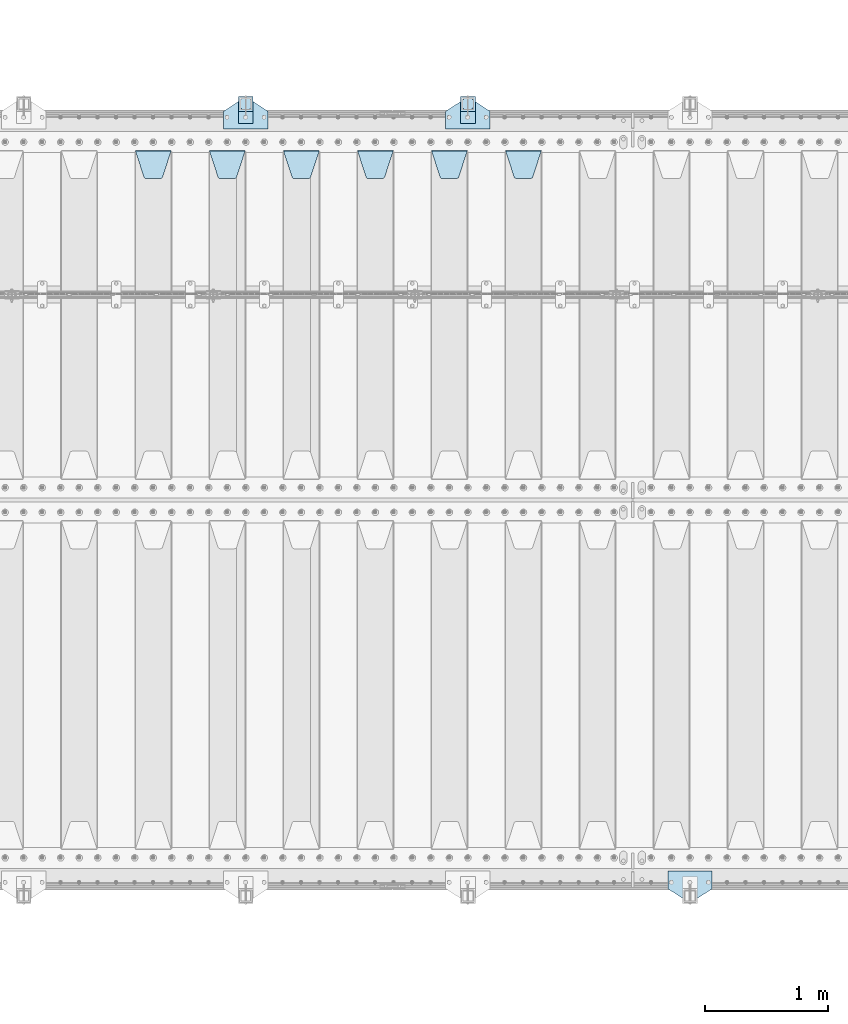
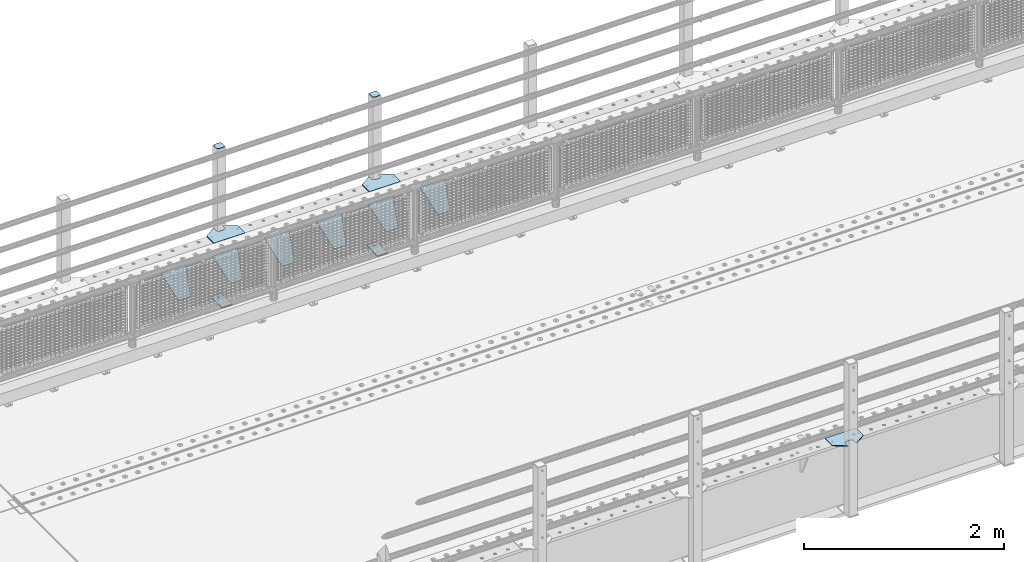
# One storey, part 204 of 242: 15 plates.
"""IFC2X3 building model written with IfcOpenShell, lengths in millimetres."""

from ifc_helpers import new_model, si_unit, frame, origin_with_axes, place, context, subcontext, project, spatial, faceted_brep, material, type_object, element, save


model = new_model("IFC2X3")

# Units and contexts
model_context = context("Model", 3, precision=1e-05, world=origin_with_axes())
body_context = subcontext(model_context, "Body", "Model", "MODEL_VIEW")
ifc_project = project(units=[si_unit("LENGTHUNIT", "METRE", prefix="MILLI"), si_unit("AREAUNIT", "SQUARE_METRE"), si_unit("VOLUMEUNIT", "CUBIC_METRE"), si_unit("MASSUNIT", "GRAM", prefix="KILO"), si_unit("TIMEUNIT", "SECOND"), si_unit("PLANEANGLEUNIT", "RADIAN"), si_unit("SOLIDANGLEUNIT", "STERADIAN"), si_unit("THERMODYNAMICTEMPERATUREUNIT", "DEGREE_CELSIUS"), si_unit("LUMINOUSINTENSITYUNIT", "LUMEN")], contexts=[model_context])

# Site, building, storey
site_placement = place(None, origin_with_axes())
site = spatial("IfcSite", under=ifc_project, at=site_placement, CompositionType="ELEMENT")
building_placement = place(site_placement, origin_with_axes())
building = spatial("IfcBuilding", under=site, at=building_placement, Name="Standard", CompositionType="ELEMENT")
storey_placement = place(building_placement, origin_with_axes())
storey = spatial("IfcBuildingStorey", under=building, at=storey_placement, Name="Undefined", CompositionType="ELEMENT", Elevation=0.0)

# Plates
ifc_material_1 = material(Name="STEEL/S355J2")
plate_type_1 = type_object("IfcPlateType", PredefinedType="NOTDEFINED")
plate_1_placement = place(storey_placement, frame((-36680.0, -17995.0, 5.00000000004911), z_axis=(0.0, 1.0, 0.0), x_axis=(1.0, 0.0, 0.0)))
element("IfcPlate", 1, at=plate_1_placement, inside=storey, type_object=plate_type_1, material=ifc_material_1, context=body_context, shape_type="Brep", body=[
    faceted_brep([(0.0, -5.0, 0.0), (2.31396552408114e-06, -5.0, 145.0), (2.31396552408114e-06, 5.0, 145.0), (0.0, 5.0, 0.0), (130.0, -5.0, 230.0), (130.0, 5.0, 230.0), (130.0, -5.0, 180.0), (130.0, 5.0, 180.0), (130.48036798992, -5.0, 175.122741949595), (130.48036798992, 5.0, 175.122741949595), (131.903011687216, -5.0, 170.432914190871), (131.903011687216, 5.0, 170.432914190871), (134.213259692435, -5.0, 166.110744174512), (134.213259692435, 5.0, 166.110744174512), (137.322330470335, -5.0, 162.322330470335), (137.322330470335, 5.0, 162.322330470335), (141.110744174512, -5.0, 159.213259692435), (141.110744174512, 5.0, 159.213259692435), (145.432914190871, -5.0, 156.903011687216), (145.432914190871, 5.0, 156.903011687216), (150.122741949595, -5.0, 155.48036798992), (150.122741949595, 5.0, 155.48036798992), (155.0, -5.0, 155.0), (155.0, 5.0, 155.0), (205.0, -5.0, 155.0), (205.0, 5.0, 155.0), (209.877258050405, -5.0, 155.48036798992), (209.877258050405, 5.0, 155.48036798992), (214.567085809129, -5.0, 156.903011687216), (214.567085809129, 5.0, 156.903011687216), (218.889255825488, -5.0, 159.213259692435), (218.889255825488, 5.0, 159.213259692435), (222.677669529665, -5.0, 162.322330470335), (222.677669529665, 5.0, 162.322330470335), (225.786740307565, -5.0, 166.110744174512), (225.786740307565, 5.0, 166.110744174512), (228.096988312784, -5.0, 170.432914190871), (228.096988312784, 5.0, 170.432914190871), (229.51963201008, -5.0, 175.122741949595), (229.51963201008, 5.0, 175.122741949595), (230.0, -5.0, 180.0), (230.0, 5.0, 180.0), (230.0, -5.0, 230.0), (230.0, 5.0, 230.0), (360.0, -5.0, 145.0), (360.0, 5.0, 145.0), (360.0, -5.0, -7.27595761418343e-12), (360.0, 5.0, -7.27595761418343e-12)], [[[0, 1, 2, 3]], [[1, 4, 5, 2]], [[4, 6, 7, 5]], [[6, 8, 9, 7]], [[8, 10, 11, 9]], [[10, 12, 13, 11]], [[12, 14, 15, 13]], [[14, 16, 17, 15]], [[16, 18, 19, 17]], [[18, 20, 21, 19]], [[20, 22, 23, 21]], [[22, 24, 25, 23]], [[24, 26, 27, 25]], [[26, 28, 29, 27]], [[28, 30, 31, 29]], [[30, 32, 33, 31]], [[32, 34, 35, 33]], [[34, 36, 37, 35]], [[36, 38, 39, 37]], [[38, 40, 41, 39]], [[40, 42, 43, 41]], [[42, 44, 45, 43]], [[44, 46, 47, 45]], [[46, 0, 3, 47]], [[5, 7, 9, 11, 13, 15, 17, 19, 21, 23, 25, 27, 29, 31, 33, 35, 37, 39, 41, 43, 45, 47, 3, 2]], [[46, 44, 42, 40, 38, 36, 34, 32, 30, 28, 26, 24, 22, 20, 18, 16, 14, 12, 10, 8, 6, 4, 1, 0]]]),
])
plate_2_placement = place(storey_placement, frame((-38480.0, -17995.0, 5.00000000004911), z_axis=(0.0, 1.0, 0.0), x_axis=(1.0, 0.0, 0.0)))
element("IfcPlate", 2, at=plate_2_placement, inside=storey, type_object=plate_type_1, material=ifc_material_1, context=body_context, shape_type="Brep", body=[
    faceted_brep([(0.0, -5.0, 0.0), (2.31396552408114e-06, -5.0, 145.0), (2.31396552408114e-06, 5.0, 145.0), (0.0, 5.0, 0.0), (130.0, -5.0, 230.0), (130.0, 5.0, 230.0), (130.0, -5.0, 180.0), (130.0, 5.0, 180.0), (130.48036798992, -5.0, 175.122741949595), (130.48036798992, 5.0, 175.122741949595), (131.903011687216, -5.0, 170.432914190871), (131.903011687216, 5.0, 170.432914190871), (134.213259692435, -5.0, 166.110744174512), (134.213259692435, 5.0, 166.110744174512), (137.322330470335, -5.0, 162.322330470335), (137.322330470335, 5.0, 162.322330470335), (141.110744174512, -5.0, 159.213259692435), (141.110744174512, 5.0, 159.213259692435), (145.432914190871, -5.0, 156.903011687216), (145.432914190871, 5.0, 156.903011687216), (150.122741949595, -5.0, 155.48036798992), (150.122741949595, 5.0, 155.48036798992), (155.0, -5.0, 155.0), (155.0, 5.0, 155.0), (205.0, -5.0, 155.0), (205.0, 5.0, 155.0), (209.877258050405, -5.0, 155.48036798992), (209.877258050405, 5.0, 155.48036798992), (214.567085809129, -5.0, 156.903011687216), (214.567085809129, 5.0, 156.903011687216), (218.889255825488, -5.0, 159.213259692435), (218.889255825488, 5.0, 159.213259692435), (222.677669529665, -5.0, 162.322330470335), (222.677669529665, 5.0, 162.322330470335), (225.786740307565, -5.0, 166.110744174512), (225.786740307565, 5.0, 166.110744174512), (228.096988312784, -5.0, 170.432914190871), (228.096988312784, 5.0, 170.432914190871), (229.51963201008, -5.0, 175.122741949595), (229.51963201008, 5.0, 175.122741949595), (230.0, -5.0, 180.0), (230.0, 5.0, 180.0), (230.0, -5.0, 230.0), (230.0, 5.0, 230.0), (360.0, -5.0, 145.0), (360.0, 5.0, 145.0), (360.0, -5.0, -7.27595761418343e-12), (360.0, 5.0, -7.27595761418343e-12)], [[[0, 1, 2, 3]], [[1, 4, 5, 2]], [[4, 6, 7, 5]], [[6, 8, 9, 7]], [[8, 10, 11, 9]], [[10, 12, 13, 11]], [[12, 14, 15, 13]], [[14, 16, 17, 15]], [[16, 18, 19, 17]], [[18, 20, 21, 19]], [[20, 22, 23, 21]], [[22, 24, 25, 23]], [[24, 26, 27, 25]], [[26, 28, 29, 27]], [[28, 30, 31, 29]], [[30, 32, 33, 31]], [[32, 34, 35, 33]], [[34, 36, 37, 35]], [[36, 38, 39, 37]], [[38, 40, 41, 39]], [[40, 42, 43, 41]], [[42, 44, 45, 43]], [[44, 46, 47, 45]], [[46, 0, 3, 47]], [[5, 7, 9, 11, 13, 15, 17, 19, 21, 23, 25, 27, 29, 31, 33, 35, 37, 39, 41, 43, 45, 47, 3, 2]], [[46, 44, 42, 40, 38, 36, 34, 32, 30, 28, 26, 24, 22, 20, 18, 16, 14, 12, 10, 8, 6, 4, 1, 0]]]),
])
plate_3_placement = place(storey_placement, frame((-34520.0, -24005.0, 5.00000000004911), z_axis=(0.0, -1.0, 0.0), x_axis=(-1.0, 0.0, 0.0)))
element("IfcPlate", 3, at=plate_3_placement, inside=storey, type_object=plate_type_1, material=ifc_material_1, context=body_context, shape_type="Brep", body=[
    faceted_brep([(0.0, -5.0, 0.0), (2.31396552408114e-06, -5.0, 145.0), (2.31396552408114e-06, 5.0, 145.0), (0.0, 5.0, 0.0), (130.0, -5.0, 230.0), (130.0, 5.0, 230.0), (130.0, -5.0, 180.0), (130.0, 5.0, 180.0), (130.48036798992, -5.0, 175.122741949595), (130.48036798992, 5.0, 175.122741949595), (131.903011687216, -5.0, 170.432914190871), (131.903011687216, 5.0, 170.432914190871), (134.213259692435, -5.0, 166.110744174512), (134.213259692435, 5.0, 166.110744174512), (137.322330470335, -5.0, 162.322330470335), (137.322330470335, 5.0, 162.322330470335), (141.110744174512, -5.0, 159.213259692435), (141.110744174512, 5.0, 159.213259692435), (145.432914190871, -5.0, 156.903011687216), (145.432914190871, 5.0, 156.903011687216), (150.122741949595, -5.0, 155.48036798992), (150.122741949595, 5.0, 155.48036798992), (155.0, -5.0, 155.0), (155.0, 5.0, 155.0), (205.0, -5.0, 155.0), (205.0, 5.0, 155.0), (209.877258050405, -5.0, 155.48036798992), (209.877258050405, 5.0, 155.48036798992), (214.567085809129, -5.0, 156.903011687216), (214.567085809129, 5.0, 156.903011687216), (218.889255825488, -5.0, 159.213259692435), (218.889255825488, 5.0, 159.213259692435), (222.677669529665, -5.0, 162.322330470335), (222.677669529665, 5.0, 162.322330470335), (225.786740307565, -5.0, 166.110744174512), (225.786740307565, 5.0, 166.110744174512), (228.096988312784, -5.0, 170.432914190871), (228.096988312784, 5.0, 170.432914190871), (229.51963201008, -5.0, 175.122741949595), (229.51963201008, 5.0, 175.122741949595), (230.0, -5.0, 180.0), (230.0, 5.0, 180.0), (230.0, -5.0, 230.0), (230.0, 5.0, 230.0), (360.0, -5.0, 145.0), (360.0, 5.0, 145.0), (360.0, -5.0, -7.27595761418343e-12), (360.0, 5.0, -7.27595761418343e-12)], [[[0, 1, 2, 3]], [[1, 4, 5, 2]], [[4, 6, 7, 5]], [[6, 8, 9, 7]], [[8, 10, 11, 9]], [[10, 12, 13, 11]], [[12, 14, 15, 13]], [[14, 16, 17, 15]], [[16, 18, 19, 17]], [[18, 20, 21, 19]], [[20, 22, 23, 21]], [[22, 24, 25, 23]], [[24, 26, 27, 25]], [[26, 28, 29, 27]], [[28, 30, 31, 29]], [[30, 32, 33, 31]], [[32, 34, 35, 33]], [[34, 36, 37, 35]], [[36, 38, 39, 37]], [[38, 40, 41, 39]], [[40, 42, 43, 41]], [[42, 44, 45, 43]], [[44, 46, 47, 45]], [[46, 0, 3, 47]], [[5, 7, 9, 11, 13, 15, 17, 19, 21, 23, 25, 27, 29, 31, 33, 35, 37, 39, 41, 43, 45, 47, 3, 2]], [[46, 44, 42, 40, 38, 36, 34, 32, 30, 28, 26, 24, 22, 20, 18, 16, 14, 12, 10, 8, 6, 4, 1, 0]]]),
])
plate_type_2 = type_object("IfcPlateType", PredefinedType="NOTDEFINED")
for number, where, z_axis, x_axis in (
    (4, (-36559.9999999999, -17949.9999999998, -850.000000000002), (0.0, 1.0, 0.0), (1.0, 0.0, 0.0)),
    (5, (-38359.9999999999, -17949.9999999998, -850.000000000002), (0.0, 1.0, 0.0), (1.0, 0.0, 0.0)),
):
    element("IfcPlate", number, at=place(storey_placement, frame(where, z_axis=z_axis, x_axis=x_axis)), inside=storey, type_object=plate_type_2, material=ifc_material_1, context=body_context, shape_type="Brep", body=[
        faceted_brep([(66.3639610305399, -5.0, 163.636038969114), (66.3639610305399, 5.0, 163.636038969114), (59.9999999998618, 5.0, 160.999999999793), (59.9999999998618, -5.0, 160.999999999793), (53.6360389691836, 5.0, 163.636038969114), (53.6360389691836, -5.0, 163.636038969114), (50.9999999998618, 5.0, 169.999999999793), (50.9999999998618, -5.0, 169.999999999793), (53.6360389691836, 5.0, 176.363961030471), (53.6360389691836, -5.0, 176.363961030471), (59.9999999998618, 5.0, 178.999999999793), (59.9999999998618, -5.0, 178.999999999793), (66.3639610305399, 5.0, 176.363961030471), (66.3639610305399, -5.0, 176.363961030471), (68.9999999998618, 5.0, 169.999999999793), (68.9999999998618, -5.0, 169.999999999793), (120.0, -5.0, 0.0), (120.0, -5.0, 220.0), (0.0, -5.0, 220.0), (0.0, -5.0, 0.0), (0.0, 5.0, 0.0), (120.0, 5.0, 0.0), (120.0, 5.0, 220.0), (0.0, 5.0, 220.0)], [[[0, 1, 2, 3]], [[3, 2, 4, 5]], [[5, 4, 6, 7]], [[7, 6, 8, 9]], [[9, 8, 10, 11]], [[11, 10, 12, 13]], [[13, 12, 14, 15]], [[15, 14, 1, 0]], [[16, 17, 18, 19], [11, 13, 15, 0, 3, 5, 7, 9]], [[16, 19, 20, 21]], [[17, 16, 21, 22]], [[18, 17, 22, 23]], [[19, 18, 23, 20]], [[22, 21, 20, 23], [2, 1, 14, 12, 10, 8, 6, 4]]]),
    ])
plate_type_3 = type_object("IfcPlateType", PredefinedType="NOTDEFINED")
plate_4_placement = place(storey_placement, frame((-36455.9999999999, -17833.9999999998, 1012.50000000001), z_axis=(0.0, 1.0, 0.0), x_axis=(-1.0, 0.0, 0.0)))
element("IfcPlate", 6, at=plate_4_placement, inside=storey, type_object=plate_type_3, material=ifc_material_1, context=body_context, shape_type="Brep", body=[
    faceted_brep([(0.0, -2.5, 19.0), (0.0, -2.5, 69.0), (0.0, 2.5, 69.0), (0.0, 2.5, 19.0), (0.476369668544066, -2.5, 73.2278977451715), (0.476369668544066, 2.5, 73.2278977451715), (1.88159150985302, -2.5, 77.2437910432345), (1.88159150985302, 2.5, 77.2437910432345), (4.14520183310742, -2.5, 80.8463062353148), (4.14520183310742, 2.5, 80.8463062353148), (7.15369376468516, -2.5, 83.8547981668926), (7.15369376468516, 2.5, 83.8547981668926), (10.7562089567655, -2.5, 86.118408490147), (10.7562089567655, 2.5, 86.118408490147), (14.7721022548285, -2.5, 87.5236303314559), (14.7721022548285, 2.5, 87.5236303314559), (19.0, -2.5, 88.0), (19.0, 2.5, 88.0), (69.0, -2.5, 88.0), (69.0, 2.5, 88.0), (73.2278977451715, -2.5, 87.5236303314559), (73.2278977451715, 2.5, 87.5236303314559), (77.2437910432345, -2.5, 86.118408490147), (77.2437910432345, 2.5, 86.118408490147), (80.8463062353148, -2.5, 83.8547981668926), (80.8463062353148, 2.5, 83.8547981668926), (83.8547981668926, -2.5, 80.8463062353148), (83.8547981668926, 2.5, 80.8463062353148), (86.118408490147, -2.5, 77.2437910432345), (86.118408490147, 2.5, 77.2437910432345), (87.5236303314559, -2.5, 73.2278977451715), (87.5236303314559, 2.5, 73.2278977451715), (88.0, -2.5, 69.0), (88.0, 2.5, 69.0), (88.0, -2.5, 19.0), (88.0, 2.5, 19.0), (87.5236303314559, -2.5, 14.7721022548285), (87.5236303314559, 2.5, 14.7721022548285), (86.118408490147, -2.5, 10.7562089567655), (86.118408490147, 2.5, 10.7562089567655), (83.8547981668926, -2.5, 7.15369376468516), (83.8547981668926, 2.5, 7.15369376468516), (80.8463062353148, -2.5, 4.14520183310742), (80.8463062353148, 2.5, 4.14520183310742), (77.2437910432345, -2.5, 1.88159150985302), (77.2437910432345, 2.5, 1.88159150985302), (73.2278977451715, -2.5, 0.476369668544066), (73.2278977451715, 2.5, 0.476369668544066), (69.0, -2.5, 0.0), (69.0, 2.5, 0.0), (19.0, -2.5, 0.0), (19.0, 2.5, 0.0), (14.7721022548285, -2.5, 0.476369668544066), (14.7721022548285, 2.5, 0.476369668544066), (10.7562089567655, -2.5, 1.88159150985302), (10.7562089567655, 2.5, 1.88159150985302), (7.15369376468516, -2.5, 4.14520183310742), (7.15369376468516, 2.5, 4.14520183310742), (4.14520183310742, -2.5, 7.15369376468516), (4.14520183310742, 2.5, 7.15369376468516), (1.88159150985302, -2.5, 10.7562089567655), (1.88159150985302, 2.5, 10.7562089567655), (0.476369668544066, -2.5, 14.7721022548285), (0.476369668544066, 2.5, 14.7721022548285)], [[[0, 1, 2, 3]], [[1, 4, 5, 2]], [[4, 6, 7, 5]], [[6, 8, 9, 7]], [[8, 10, 11, 9]], [[10, 12, 13, 11]], [[12, 14, 15, 13]], [[14, 16, 17, 15]], [[16, 18, 19, 17]], [[18, 20, 21, 19]], [[20, 22, 23, 21]], [[22, 24, 25, 23]], [[24, 26, 27, 25]], [[26, 28, 29, 27]], [[28, 30, 31, 29]], [[30, 32, 33, 31]], [[32, 34, 35, 33]], [[34, 36, 37, 35]], [[36, 38, 39, 37]], [[38, 40, 41, 39]], [[40, 42, 43, 41]], [[42, 44, 45, 43]], [[44, 46, 47, 45]], [[46, 48, 49, 47]], [[48, 50, 51, 49]], [[50, 52, 53, 51]], [[52, 54, 55, 53]], [[54, 56, 57, 55]], [[56, 58, 59, 57]], [[58, 60, 61, 59]], [[60, 62, 63, 61]], [[62, 0, 3, 63]], [[5, 7, 9, 11, 13, 15, 17, 19, 21, 23, 25, 27, 29, 31, 33, 35, 37, 39, 41, 43, 45, 47, 49, 51, 53, 55, 57, 59, 61, 63, 3, 2]], [[62, 60, 58, 56, 54, 52, 50, 48, 46, 44, 42, 40, 38, 36, 34, 32, 30, 28, 26, 24, 22, 20, 18, 16, 14, 12, 10, 8, 6, 4, 1, 0]]]),
])
plate_5_placement = place(storey_placement, frame((-38255.9999999999, -17833.9999999998, 1012.50000000001), z_axis=(0.0, 1.0, 0.0), x_axis=(-1.0, 0.0, 0.0)))
element("IfcPlate", 7, at=plate_5_placement, inside=storey, type_object=plate_type_3, material=ifc_material_1, context=body_context, shape_type="Brep", body=[
    faceted_brep([(0.0, -2.5, 19.0), (0.0, -2.5, 69.0), (0.0, 2.5, 69.0), (0.0, 2.5, 19.0), (0.476369668544066, -2.5, 73.2278977451715), (0.476369668544066, 2.5, 73.2278977451715), (1.88159150985302, -2.5, 77.2437910432345), (1.88159150985302, 2.5, 77.2437910432345), (4.14520183310742, -2.5, 80.8463062353148), (4.14520183310742, 2.5, 80.8463062353148), (7.15369376468516, -2.5, 83.8547981668926), (7.15369376468516, 2.5, 83.8547981668926), (10.7562089567655, -2.5, 86.118408490147), (10.7562089567655, 2.5, 86.118408490147), (14.7721022548285, -2.5, 87.5236303314559), (14.7721022548285, 2.5, 87.5236303314559), (19.0, -2.5, 88.0), (19.0, 2.5, 88.0), (69.0, -2.5, 88.0), (69.0, 2.5, 88.0), (73.2278977451715, -2.5, 87.5236303314559), (73.2278977451715, 2.5, 87.5236303314559), (77.2437910432345, -2.5, 86.118408490147), (77.2437910432345, 2.5, 86.118408490147), (80.8463062353148, -2.5, 83.8547981668926), (80.8463062353148, 2.5, 83.8547981668926), (83.8547981668926, -2.5, 80.8463062353148), (83.8547981668926, 2.5, 80.8463062353148), (86.118408490147, -2.5, 77.2437910432345), (86.118408490147, 2.5, 77.2437910432345), (87.5236303314559, -2.5, 73.2278977451715), (87.5236303314559, 2.5, 73.2278977451715), (88.0, -2.5, 69.0), (88.0, 2.5, 69.0), (88.0, -2.5, 19.0), (88.0, 2.5, 19.0), (87.5236303314559, -2.5, 14.7721022548285), (87.5236303314559, 2.5, 14.7721022548285), (86.118408490147, -2.5, 10.7562089567655), (86.118408490147, 2.5, 10.7562089567655), (83.8547981668926, -2.5, 7.15369376468516), (83.8547981668926, 2.5, 7.15369376468516), (80.8463062353148, -2.5, 4.14520183310742), (80.8463062353148, 2.5, 4.14520183310742), (77.2437910432345, -2.5, 1.88159150985302), (77.2437910432345, 2.5, 1.88159150985302), (73.2278977451715, -2.5, 0.476369668544066), (73.2278977451715, 2.5, 0.476369668544066), (69.0, -2.5, 0.0), (69.0, 2.5, 0.0), (19.0, -2.5, 0.0), (19.0, 2.5, 0.0), (14.7721022548285, -2.5, 0.476369668544066), (14.7721022548285, 2.5, 0.476369668544066), (10.7562089567655, -2.5, 1.88159150985302), (10.7562089567655, 2.5, 1.88159150985302), (7.15369376468516, -2.5, 4.14520183310742), (7.15369376468516, 2.5, 4.14520183310742), (4.14520183310742, -2.5, 7.15369376468516), (4.14520183310742, 2.5, 7.15369376468516), (1.88159150985302, -2.5, 10.7562089567655), (1.88159150985302, 2.5, 10.7562089567655), (0.476369668544066, -2.5, 14.7721022548285), (0.476369668544066, 2.5, 14.7721022548285)], [[[0, 1, 2, 3]], [[1, 4, 5, 2]], [[4, 6, 7, 5]], [[6, 8, 9, 7]], [[8, 10, 11, 9]], [[10, 12, 13, 11]], [[12, 14, 15, 13]], [[14, 16, 17, 15]], [[16, 18, 19, 17]], [[18, 20, 21, 19]], [[20, 22, 23, 21]], [[22, 24, 25, 23]], [[24, 26, 27, 25]], [[26, 28, 29, 27]], [[28, 30, 31, 29]], [[30, 32, 33, 31]], [[32, 34, 35, 33]], [[34, 36, 37, 35]], [[36, 38, 39, 37]], [[38, 40, 41, 39]], [[40, 42, 43, 41]], [[42, 44, 45, 43]], [[44, 46, 47, 45]], [[46, 48, 49, 47]], [[48, 50, 51, 49]], [[50, 52, 53, 51]], [[52, 54, 55, 53]], [[54, 56, 57, 55]], [[56, 58, 59, 57]], [[58, 60, 61, 59]], [[60, 62, 63, 61]], [[62, 0, 3, 63]], [[5, 7, 9, 11, 13, 15, 17, 19, 21, 23, 25, 27, 29, 31, 33, 35, 37, 39, 41, 43, 45, 47, 49, 51, 53, 55, 57, 59, 61, 63, 3, 2]], [[62, 60, 58, 56, 54, 52, 50, 48, 46, 44, 42, 40, 38, 36, 34, 32, 30, 28, 26, 24, 22, 20, 18, 16, 14, 12, 10, 8, 6, 4, 1, 0]]]),
])
plate_type_4 = type_object("IfcPlateType", PredefinedType="NOTDEFINED")
for number, where, z_axis, x_axis in (
    (8, (-36559.9999999999, -17949.9999999998, -857.500000000002), (0.0, 1.0, 0.0), (1.0, 0.0, 0.0)),
    (9, (-38359.9999999999, -17949.9999999998, -857.500000000002), (0.0, 1.0, 0.0), (1.0, 0.0, 0.0)),
):
    element("IfcPlate", number, at=place(storey_placement, frame(where, z_axis=z_axis, x_axis=x_axis)), inside=storey, type_object=plate_type_4, material=ifc_material_1, context=body_context, shape_type="Brep", body=[
        faceted_brep([(0.0, -2.5, 0.0), (0.0, -2.5, 100.0), (0.0, 2.5, 100.0), (0.0, 2.5, 0.0), (120.0, -2.5, 100.0), (120.0, 2.5, 100.0), (120.0, -2.5, 0.0), (120.0, 2.5, 0.0)], [[[0, 1, 2, 3]], [[1, 4, 5, 2]], [[4, 6, 7, 5]], [[6, 0, 3, 7]], [[5, 7, 3, 2]], [[6, 4, 1, 0]]]),
    ])
ifc_material_2 = material(Name="STEEL/S355N")
plate_type_5 = type_object("IfcPlateType", PredefinedType="NOTDEFINED")
plate_6_placement = place(storey_placement, frame((-36195.0, -18168.2322330441, -1.76776695296576), z_axis=(0.0, -0.707106781186547, -0.707106781186548), x_axis=(1.0, 0.0, 0.0)))
element("IfcPlate", 10, at=plate_6_placement, inside=storey, type_object=plate_type_5, material=ifc_material_2, context=body_context, shape_type="Brep", body=[
    faceted_brep([(0.0, -2.5, 0.0), (69.345504679477, -2.50000000000182, 300.171731424829), (69.345504679477, 2.5, 300.171731424829), (0.0, 2.5, 0.0), (70.9274061199576, -2.5, 304.897442415398), (70.9274061199576, 2.5, 304.897442415398), (73.3818627772307, -2.5, 309.234538108525), (73.3818627772307, 2.50000000000182, 309.234538108529), (76.6187032999551, -2.5, 313.023683126101), (76.6187032999551, 2.50000000000182, 313.023683126103), (80.5190132704993, -2.5, 316.12567259537), (80.5190132704993, 2.5, 316.12567259537), (84.9395038596849, -2.5, 318.426546230474), (84.9395038596849, 2.50000000000182, 318.426546230476), (89.7177759439219, -2.49999999999818, 319.841774983273), (89.7177759439219, 2.50000000000182, 319.841774983273), (94.678286292652, -2.5, 320.319366455076), (94.678286292652, 2.5, 320.319366455076), (195.321713707348, -2.5, 320.319366455076), (195.321713707348, 2.5, 320.319366455076), (200.282224056078, -2.5, 319.841774983272), (200.282224056078, 2.50000000000182, 319.841774983273), (205.060496140315, -2.5, 318.426546230474), (205.060496140315, 2.49999999999818, 318.426546230474), (209.480986729501, -2.49999999999818, 316.12567259537), (209.480986729501, 2.5, 316.12567259537), (213.381296700045, -2.5, 313.023683126101), (213.381296700045, 2.49999999999818, 313.023683126101), (216.618137222769, -2.5, 309.234538108525), (216.618137222769, 2.5, 309.234538108523), (219.072593880042, -2.49999999999818, 304.897442415398), (219.072593880042, 2.50000000000182, 304.897442415398), (220.654495320523, -2.50000000000182, 300.171731424829), (220.654495320523, 2.5, 300.171731424829), (290.0, -2.5, 0.0), (290.0, 2.5, -1.81898940354586e-12)], [[[0, 1, 2, 3]], [[1, 4, 5, 2]], [[4, 6, 7, 5]], [[6, 8, 9, 7]], [[8, 10, 11, 9]], [[10, 12, 13, 11]], [[12, 14, 15, 13]], [[14, 16, 17, 15]], [[16, 18, 19, 17]], [[18, 20, 21, 19]], [[20, 22, 23, 21]], [[22, 24, 25, 23]], [[24, 26, 27, 25]], [[26, 28, 29, 27]], [[28, 30, 31, 29]], [[30, 32, 33, 31]], [[32, 34, 35, 33]], [[34, 0, 3, 35]], [[5, 7, 9, 11, 13, 15, 17, 19, 21, 23, 25, 27, 29, 31, 33, 35, 3, 2]], [[34, 32, 30, 28, 26, 24, 22, 20, 18, 16, 14, 12, 10, 8, 6, 4, 1, 0]]]),
])
plate_7_placement = place(storey_placement, frame((-36795.0, -18168.2322330441, -1.76776695296576), z_axis=(0.0, -0.707106781186547, -0.707106781186548), x_axis=(1.0, 0.0, 0.0)))
element("IfcPlate", 11, at=plate_7_placement, inside=storey, type_object=plate_type_5, material=ifc_material_2, context=body_context, shape_type="Brep", body=[
    faceted_brep([(0.0, -2.5, 0.0), (69.345504679477, -2.50000000000182, 300.171731424829), (69.345504679477, 2.5, 300.171731424829), (0.0, 2.5, 0.0), (70.9274061199576, -2.5, 304.897442415398), (70.9274061199576, 2.5, 304.897442415398), (73.3818627772307, -2.5, 309.234538108525), (73.3818627772307, 2.50000000000182, 309.234538108529), (76.6187032999551, -2.5, 313.023683126101), (76.6187032999551, 2.50000000000182, 313.023683126103), (80.5190132704993, -2.5, 316.12567259537), (80.5190132704993, 2.5, 316.12567259537), (84.9395038596849, -2.5, 318.426546230474), (84.9395038596849, 2.50000000000182, 318.426546230476), (89.7177759439219, -2.49999999999818, 319.841774983273), (89.7177759439219, 2.50000000000182, 319.841774983273), (94.678286292652, -2.5, 320.319366455076), (94.678286292652, 2.5, 320.319366455076), (195.321713707348, -2.5, 320.319366455076), (195.321713707348, 2.5, 320.319366455076), (200.282224056078, -2.5, 319.841774983272), (200.282224056078, 2.50000000000182, 319.841774983273), (205.060496140315, -2.5, 318.426546230474), (205.060496140315, 2.49999999999818, 318.426546230474), (209.480986729501, -2.49999999999818, 316.12567259537), (209.480986729501, 2.5, 316.12567259537), (213.381296700045, -2.5, 313.023683126101), (213.381296700045, 2.49999999999818, 313.023683126101), (216.618137222769, -2.5, 309.234538108525), (216.618137222769, 2.5, 309.234538108523), (219.072593880042, -2.49999999999818, 304.897442415398), (219.072593880042, 2.50000000000182, 304.897442415398), (220.654495320523, -2.50000000000182, 300.171731424829), (220.654495320523, 2.5, 300.171731424829), (290.0, -2.5, 0.0), (290.0, 2.5, -1.81898940354586e-12)], [[[0, 1, 2, 3]], [[1, 4, 5, 2]], [[4, 6, 7, 5]], [[6, 8, 9, 7]], [[8, 10, 11, 9]], [[10, 12, 13, 11]], [[12, 14, 15, 13]], [[14, 16, 17, 15]], [[16, 18, 19, 17]], [[18, 20, 21, 19]], [[20, 22, 23, 21]], [[22, 24, 25, 23]], [[24, 26, 27, 25]], [[26, 28, 29, 27]], [[28, 30, 31, 29]], [[30, 32, 33, 31]], [[32, 34, 35, 33]], [[34, 0, 3, 35]], [[5, 7, 9, 11, 13, 15, 17, 19, 21, 23, 25, 27, 29, 31, 33, 35, 3, 2]], [[34, 32, 30, 28, 26, 24, 22, 20, 18, 16, 14, 12, 10, 8, 6, 4, 1, 0]]]),
])
plate_8_placement = place(storey_placement, frame((-37395.0, -18168.2322330441, -1.76776695296576), z_axis=(0.0, -0.707106781186547, -0.707106781186548), x_axis=(1.0, 0.0, 0.0)))
element("IfcPlate", 12, at=plate_8_placement, inside=storey, type_object=plate_type_5, material=ifc_material_2, context=body_context, shape_type="Brep", body=[
    faceted_brep([(0.0, -2.5, 0.0), (69.345504679477, -2.50000000000182, 300.171731424829), (69.345504679477, 2.5, 300.171731424829), (0.0, 2.5, 0.0), (70.9274061199576, -2.5, 304.897442415398), (70.9274061199576, 2.5, 304.897442415398), (73.3818627772307, -2.5, 309.234538108525), (73.3818627772307, 2.50000000000182, 309.234538108529), (76.6187032999551, -2.5, 313.023683126101), (76.6187032999551, 2.50000000000182, 313.023683126103), (80.5190132704993, -2.5, 316.12567259537), (80.5190132704993, 2.5, 316.12567259537), (84.9395038596849, -2.5, 318.426546230474), (84.9395038596849, 2.50000000000182, 318.426546230476), (89.7177759439219, -2.49999999999818, 319.841774983273), (89.7177759439219, 2.50000000000182, 319.841774983273), (94.678286292652, -2.5, 320.319366455076), (94.678286292652, 2.5, 320.319366455076), (195.321713707348, -2.5, 320.319366455076), (195.321713707348, 2.5, 320.319366455076), (200.282224056078, -2.5, 319.841774983272), (200.282224056078, 2.50000000000182, 319.841774983273), (205.060496140315, -2.5, 318.426546230474), (205.060496140315, 2.49999999999818, 318.426546230474), (209.480986729501, -2.49999999999818, 316.12567259537), (209.480986729501, 2.5, 316.12567259537), (213.381296700045, -2.5, 313.023683126101), (213.381296700045, 2.49999999999818, 313.023683126101), (216.618137222769, -2.5, 309.234538108525), (216.618137222769, 2.5, 309.234538108523), (219.072593880042, -2.49999999999818, 304.897442415398), (219.072593880042, 2.50000000000182, 304.897442415398), (220.654495320523, -2.50000000000182, 300.171731424829), (220.654495320523, 2.5, 300.171731424829), (290.0, -2.5, 0.0), (290.0, 2.5, -1.81898940354586e-12)], [[[0, 1, 2, 3]], [[1, 4, 5, 2]], [[4, 6, 7, 5]], [[6, 8, 9, 7]], [[8, 10, 11, 9]], [[10, 12, 13, 11]], [[12, 14, 15, 13]], [[14, 16, 17, 15]], [[16, 18, 19, 17]], [[18, 20, 21, 19]], [[20, 22, 23, 21]], [[22, 24, 25, 23]], [[24, 26, 27, 25]], [[26, 28, 29, 27]], [[28, 30, 31, 29]], [[30, 32, 33, 31]], [[32, 34, 35, 33]], [[34, 0, 3, 35]], [[5, 7, 9, 11, 13, 15, 17, 19, 21, 23, 25, 27, 29, 31, 33, 35, 3, 2]], [[34, 32, 30, 28, 26, 24, 22, 20, 18, 16, 14, 12, 10, 8, 6, 4, 1, 0]]]),
])
plate_9_placement = place(storey_placement, frame((-37995.0, -18168.2322330441, -1.76776695296576), z_axis=(0.0, -0.707106781186547, -0.707106781186548), x_axis=(1.0, 0.0, 0.0)))
element("IfcPlate", 13, at=plate_9_placement, inside=storey, type_object=plate_type_5, material=ifc_material_2, context=body_context, shape_type="Brep", body=[
    faceted_brep([(0.0, -2.5, 0.0), (69.345504679477, -2.50000000000182, 300.171731424829), (69.345504679477, 2.5, 300.171731424829), (0.0, 2.5, 0.0), (70.9274061199576, -2.5, 304.897442415398), (70.9274061199576, 2.5, 304.897442415398), (73.3818627772307, -2.5, 309.234538108525), (73.3818627772307, 2.50000000000182, 309.234538108529), (76.6187032999551, -2.5, 313.023683126101), (76.6187032999551, 2.50000000000182, 313.023683126103), (80.5190132704993, -2.5, 316.12567259537), (80.5190132704993, 2.5, 316.12567259537), (84.9395038596849, -2.5, 318.426546230474), (84.9395038596849, 2.50000000000182, 318.426546230476), (89.7177759439219, -2.49999999999818, 319.841774983273), (89.7177759439219, 2.50000000000182, 319.841774983273), (94.678286292652, -2.5, 320.319366455076), (94.678286292652, 2.5, 320.319366455076), (195.321713707348, -2.5, 320.319366455076), (195.321713707348, 2.5, 320.319366455076), (200.282224056078, -2.5, 319.841774983272), (200.282224056078, 2.50000000000182, 319.841774983273), (205.060496140315, -2.5, 318.426546230474), (205.060496140315, 2.49999999999818, 318.426546230474), (209.480986729501, -2.49999999999818, 316.12567259537), (209.480986729501, 2.5, 316.12567259537), (213.381296700045, -2.5, 313.023683126101), (213.381296700045, 2.49999999999818, 313.023683126101), (216.618137222769, -2.5, 309.234538108525), (216.618137222769, 2.5, 309.234538108523), (219.072593880042, -2.49999999999818, 304.897442415398), (219.072593880042, 2.50000000000182, 304.897442415398), (220.654495320523, -2.50000000000182, 300.171731424829), (220.654495320523, 2.5, 300.171731424829), (290.0, -2.5, 0.0), (290.0, 2.5, -1.81898940354586e-12)], [[[0, 1, 2, 3]], [[1, 4, 5, 2]], [[4, 6, 7, 5]], [[6, 8, 9, 7]], [[8, 10, 11, 9]], [[10, 12, 13, 11]], [[12, 14, 15, 13]], [[14, 16, 17, 15]], [[16, 18, 19, 17]], [[18, 20, 21, 19]], [[20, 22, 23, 21]], [[22, 24, 25, 23]], [[24, 26, 27, 25]], [[26, 28, 29, 27]], [[28, 30, 31, 29]], [[30, 32, 33, 31]], [[32, 34, 35, 33]], [[34, 0, 3, 35]], [[5, 7, 9, 11, 13, 15, 17, 19, 21, 23, 25, 27, 29, 31, 33, 35, 3, 2]], [[34, 32, 30, 28, 26, 24, 22, 20, 18, 16, 14, 12, 10, 8, 6, 4, 1, 0]]]),
])
plate_10_placement = place(storey_placement, frame((-38595.0, -18168.2322330441, -1.76776695296576), z_axis=(0.0, -0.707106781186547, -0.707106781186548), x_axis=(1.0, 0.0, 0.0)))
element("IfcPlate", 14, at=plate_10_placement, inside=storey, type_object=plate_type_5, material=ifc_material_2, context=body_context, shape_type="Brep", body=[
    faceted_brep([(0.0, -2.5, 0.0), (69.345504679477, -2.50000000000182, 300.171731424829), (69.345504679477, 2.5, 300.171731424829), (0.0, 2.5, 0.0), (70.9274061199576, -2.5, 304.897442415398), (70.9274061199576, 2.5, 304.897442415398), (73.3818627772307, -2.5, 309.234538108525), (73.3818627772307, 2.50000000000182, 309.234538108529), (76.6187032999551, -2.5, 313.023683126101), (76.6187032999551, 2.50000000000182, 313.023683126103), (80.5190132704993, -2.5, 316.12567259537), (80.5190132704993, 2.5, 316.12567259537), (84.9395038596849, -2.5, 318.426546230474), (84.9395038596849, 2.50000000000182, 318.426546230476), (89.7177759439219, -2.49999999999818, 319.841774983273), (89.7177759439219, 2.50000000000182, 319.841774983273), (94.678286292652, -2.5, 320.319366455076), (94.678286292652, 2.5, 320.319366455076), (195.321713707348, -2.5, 320.319366455076), (195.321713707348, 2.5, 320.319366455076), (200.282224056078, -2.5, 319.841774983272), (200.282224056078, 2.50000000000182, 319.841774983273), (205.060496140315, -2.5, 318.426546230474), (205.060496140315, 2.49999999999818, 318.426546230474), (209.480986729501, -2.49999999999818, 316.12567259537), (209.480986729501, 2.5, 316.12567259537), (213.381296700045, -2.5, 313.023683126101), (213.381296700045, 2.49999999999818, 313.023683126101), (216.618137222769, -2.5, 309.234538108525), (216.618137222769, 2.5, 309.234538108523), (219.072593880042, -2.49999999999818, 304.897442415398), (219.072593880042, 2.50000000000182, 304.897442415398), (220.654495320523, -2.50000000000182, 300.171731424829), (220.654495320523, 2.5, 300.171731424829), (290.0, -2.5, 0.0), (290.0, 2.5, -1.81898940354586e-12)], [[[0, 1, 2, 3]], [[1, 4, 5, 2]], [[4, 6, 7, 5]], [[6, 8, 9, 7]], [[8, 10, 11, 9]], [[10, 12, 13, 11]], [[12, 14, 15, 13]], [[14, 16, 17, 15]], [[16, 18, 19, 17]], [[18, 20, 21, 19]], [[20, 22, 23, 21]], [[22, 24, 25, 23]], [[24, 26, 27, 25]], [[26, 28, 29, 27]], [[28, 30, 31, 29]], [[30, 32, 33, 31]], [[32, 34, 35, 33]], [[34, 0, 3, 35]], [[5, 7, 9, 11, 13, 15, 17, 19, 21, 23, 25, 27, 29, 31, 33, 35, 3, 2]], [[34, 32, 30, 28, 26, 24, 22, 20, 18, 16, 14, 12, 10, 8, 6, 4, 1, 0]]]),
])
plate_11_placement = place(storey_placement, frame((-39195.0, -18168.2322330441, -1.76776695296576), z_axis=(0.0, -0.707106781186547, -0.707106781186548), x_axis=(1.0, 0.0, 0.0)))
element("IfcPlate", 15, at=plate_11_placement, inside=storey, type_object=plate_type_5, material=ifc_material_2, context=body_context, shape_type="Brep", body=[
    faceted_brep([(0.0, -2.5, 0.0), (69.345504679477, -2.50000000000182, 300.171731424829), (69.345504679477, 2.5, 300.171731424829), (0.0, 2.5, 0.0), (70.9274061199576, -2.5, 304.897442415398), (70.9274061199576, 2.5, 304.897442415398), (73.3818627772307, -2.5, 309.234538108525), (73.3818627772307, 2.50000000000182, 309.234538108529), (76.6187032999551, -2.5, 313.023683126101), (76.6187032999551, 2.50000000000182, 313.023683126103), (80.5190132704993, -2.5, 316.12567259537), (80.5190132704993, 2.5, 316.12567259537), (84.9395038596849, -2.5, 318.426546230474), (84.9395038596849, 2.50000000000182, 318.426546230476), (89.7177759439219, -2.49999999999818, 319.841774983273), (89.7177759439219, 2.50000000000182, 319.841774983273), (94.678286292652, -2.5, 320.319366455076), (94.678286292652, 2.5, 320.319366455076), (195.321713707348, -2.5, 320.319366455076), (195.321713707348, 2.5, 320.319366455076), (200.282224056078, -2.5, 319.841774983272), (200.282224056078, 2.50000000000182, 319.841774983273), (205.060496140315, -2.5, 318.426546230474), (205.060496140315, 2.49999999999818, 318.426546230474), (209.480986729501, -2.49999999999818, 316.12567259537), (209.480986729501, 2.5, 316.12567259537), (213.381296700045, -2.5, 313.023683126101), (213.381296700045, 2.49999999999818, 313.023683126101), (216.618137222769, -2.5, 309.234538108525), (216.618137222769, 2.5, 309.234538108523), (219.072593880042, -2.49999999999818, 304.897442415398), (219.072593880042, 2.50000000000182, 304.897442415398), (220.654495320523, -2.50000000000182, 300.171731424829), (220.654495320523, 2.5, 300.171731424829), (290.0, -2.5, 0.0), (290.0, 2.5, -1.81898940354586e-12)], [[[0, 1, 2, 3]], [[1, 4, 5, 2]], [[4, 6, 7, 5]], [[6, 8, 9, 7]], [[8, 10, 11, 9]], [[10, 12, 13, 11]], [[12, 14, 15, 13]], [[14, 16, 17, 15]], [[16, 18, 19, 17]], [[18, 20, 21, 19]], [[20, 22, 23, 21]], [[22, 24, 25, 23]], [[24, 26, 27, 25]], [[26, 28, 29, 27]], [[28, 30, 31, 29]], [[30, 32, 33, 31]], [[32, 34, 35, 33]], [[34, 0, 3, 35]], [[5, 7, 9, 11, 13, 15, 17, 19, 21, 23, 25, 27, 29, 31, 33, 35, 3, 2]], [[34, 32, 30, 28, 26, 24, 22, 20, 18, 16, 14, 12, 10, 8, 6, 4, 1, 0]]]),
])

save(model, "model.ifc")
